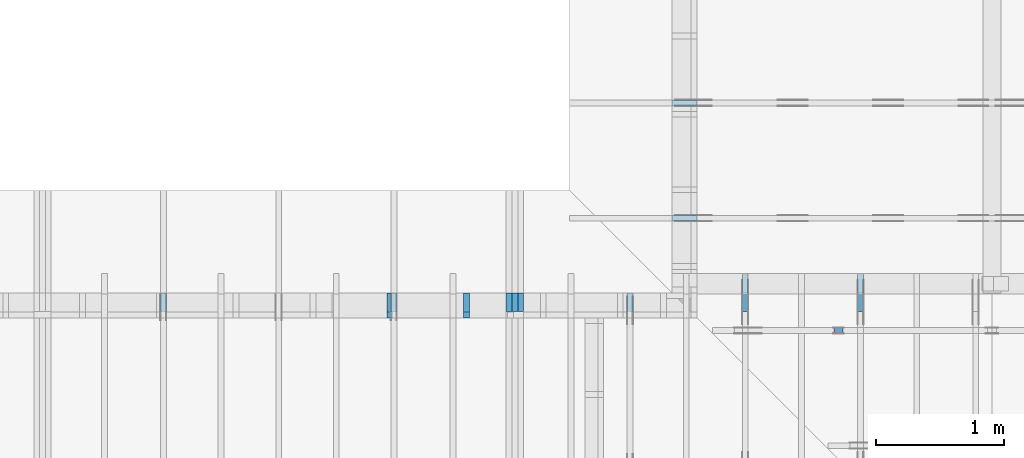
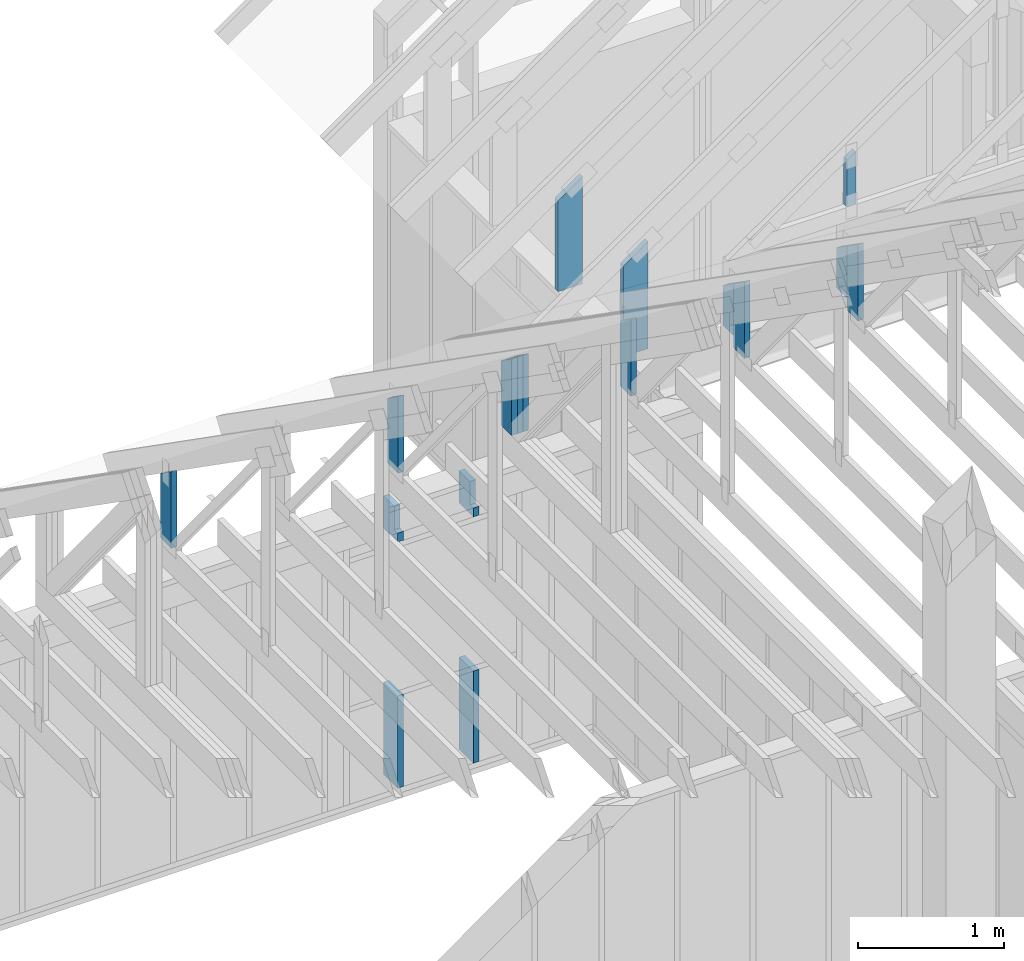
# One storey, part 41 of 70: 17 members, 10 elements without a shape of their own.
"""IFC2X3 building model written with IfcOpenShell, lengths in millimetres."""

from ifc_helpers import new_model, si_unit, frame, origin, origin_with_axes, origin_2d, place, context, project, spatial, faceted_brep, element, aggregate, save


model = new_model("IFC2X3")

# Units and contexts
model_context = context("Model", 3, precision=1e-05, world=origin())
plan_context = context("Plan", 2, precision=1e-05, world=origin_2d())
ifc_project = project(units=[si_unit("LENGTHUNIT", "METRE", prefix="MILLI"), si_unit("AREAUNIT", "SQUARE_METRE"), si_unit("VOLUMEUNIT", "CUBIC_METRE"), si_unit("SOLIDANGLEUNIT", "STERADIAN"), si_unit("PLANEANGLEUNIT", "RADIAN"), si_unit("MASSUNIT", "GRAM"), si_unit("TIMEUNIT", "SECOND"), si_unit("THERMODYNAMICTEMPERATUREUNIT", "DEGREE_CELSIUS"), si_unit("LUMINOUSINTENSITYUNIT", "LUMEN")], contexts=[model_context, plan_context])

# Site, building, storey
site_placement = place(None, origin_with_axes())
site = spatial("IfcSite", under=ifc_project, at=site_placement, CompositionType="ELEMENT")
building_placement = place(site_placement, origin_with_axes())
building = spatial("IfcBuilding", under=site, at=building_placement, Name="Layout 1", CompositionType="ELEMENT")
storey_placement = place(building_placement, origin_with_axes())
storey = spatial("IfcBuildingStorey", under=building, at=storey_placement, Name="Storey 1", CompositionType="ELEMENT", Elevation=0.0)

# Assembly, members
assembly_1_placement = place(storey_placement, frame((5660.000000000293, 8000.0, 9.122500660690286e-13), z_axis=(-1.0, 1.836909530733566e-16, 6.123031769111886e-17), x_axis=(-1.836909530733566e-16, -1.0, 0.0)))
assembly_1 = element("IfcElementAssembly", 1, at=assembly_1_placement, inside=storey, Name="T11", AssemblyPlace="FACTORY", PredefinedType="TRUSS")
member_1_placement = place(assembly_1_placement, frame((145.00000000010297, 220.00000000000085, -90.0), z_axis=(0.0, 0.0, 1.0), x_axis=(-1.7151265217091316e-15, 1.0, 0.0)))
member_1 = element("IfcMember", 2, at=member_1_placement, Name="E3", context=model_context, shape_type="Brep", body=[
    faceted_brep([(541.9489551912696, 145.00000000010203, 45.0), (2.5579538487363607e-13, 145.00000000010203, 45.0), (0.0, 1.9656170024973108e-09, 45.0), (643.4790482318778, 1.9656170024973108e-09, 45.0), (2.5579538487363607e-13, 145.00000000010203, 3.1324865359469514e-29), (541.9489551912696, 145.00000000010203, 6.636741339746276e-14), (643.4790482318778, 1.9656170024973108e-09, 7.880085310163335e-14), (0.0, 1.9656170024973108e-09, 0.0), (2.647930527585373e-25, 1.9656170024973108e-09, -1.6213362742806436e-41), (2.755364296365142e-15, 1.9656170024973108e-09, 45.0), (2.780838981362891e-13, 145.00000000010297, 45.0), (2.7532853384018877e-13, 145.00000000010297, -1.196020916729972e-30), (643.4790482318778, 2.706308139644939e-14, -1.657081071607727e-30), (643.4790482318778, 2.981844569254974e-14, 45.0), (8.416616445392925e-27, 1.965619757861607e-09, 45.0), (0.0, 1.9656170024973108e-09, 0.0), (541.9489551912698, 145.00000000010206, 6.310887241768095e-30), (541.9489551912698, 145.00000000010206, 45.0), (643.4790482318779, 0.0, 45.0), (643.4790482318779, 0.0, 6.310887241768095e-30), (2.5579538487363607e-13, 145.00000000010297, 0.0), (2.5579538487363607e-13, 145.00000000010297, 45.0), (541.9489551912696, 145.00000000010198, 45.0), (541.9489551912696, 145.00000000010198, -4.733165431326071e-30)], [[[0, 1, 2, 3]], [[4, 5, 6, 7]], [[8, 9, 10, 11]], [[12, 13, 14, 15]], [[16, 17, 18, 19]], [[20, 21, 22, 23]]]),
])
member_2_placement = place(assembly_1_placement, frame((145.00000000010297, 220.00000000000085, -135.0), z_axis=(0.0, 0.0, 1.0), x_axis=(-1.7151265217091316e-15, 1.0, 0.0)))
member_2 = element("IfcMember", 3, at=member_2_placement, Name="E3", context=model_context, shape_type="Brep", body=[
    faceted_brep([(541.9489551912696, 145.00000000010203, 45.0), (2.5579538487363607e-13, 145.00000000010203, 45.0), (0.0, 1.9656170024973108e-09, 45.0), (643.4790482318778, 1.9656170024973108e-09, 45.0), (2.5579538487363607e-13, 145.00000000010203, 3.1324865359469514e-29), (541.9489551912696, 145.00000000010203, 6.636741339746276e-14), (643.4790482318778, 1.9656170024973108e-09, 7.880085310163335e-14), (0.0, 1.9656170024973108e-09, 0.0), (2.647930527585373e-25, 1.9656170024973108e-09, -1.6213362742806436e-41), (2.755364296365142e-15, 1.9656170024973108e-09, 45.0), (2.780838981362891e-13, 145.00000000010297, 45.0), (2.7532853384018877e-13, 145.00000000010297, -1.196020916729972e-30), (643.4790482318778, 2.706308139644939e-14, -1.657081071607727e-30), (643.4790482318778, 2.981844569254974e-14, 45.0), (8.416616445392925e-27, 1.965619757861607e-09, 45.0), (0.0, 1.9656170024973108e-09, 0.0), (541.9489551912698, 145.00000000010206, 6.310887241768095e-30), (541.9489551912698, 145.00000000010206, 45.0), (643.4790482318779, 0.0, 45.0), (643.4790482318779, 0.0, 6.310887241768095e-30), (2.5579538487363607e-13, 145.00000000010297, 0.0), (2.5579538487363607e-13, 145.00000000010297, 45.0), (541.9489551912696, 145.00000000010198, 45.0), (541.9489551912696, 145.00000000010198, -4.733165431326071e-30)], [[[0, 1, 2, 3]], [[4, 5, 6, 7]], [[8, 9, 10, 11]], [[12, 13, 14, 15]], [[16, 17, 18, 19]], [[20, 21, 22, 23]]]),
])
member_3_placement = place(assembly_1_placement, frame((145.00000000010297, 220.00000000000085, -180.0), z_axis=(0.0, 0.0, 1.0), x_axis=(-1.7151265217091316e-15, 1.0, 0.0)))
member_3 = element("IfcMember", 4, at=member_3_placement, Name="E3", context=model_context, shape_type="Brep", body=[
    faceted_brep([(541.9489551912696, 145.00000000010203, 45.0), (2.5579538487363607e-13, 145.00000000010203, 45.0), (0.0, 1.9656170024973108e-09, 45.0), (643.4790482318778, 1.9656170024973108e-09, 45.0), (2.5579538487363607e-13, 145.00000000010203, 3.1324865359469514e-29), (541.9489551912696, 145.00000000010203, 6.636741339746276e-14), (643.4790482318778, 1.9656170024973108e-09, 7.880085310163335e-14), (0.0, 1.9656170024973108e-09, 0.0), (2.647930527585373e-25, 1.9656170024973108e-09, -1.6213362742806436e-41), (2.755364296365142e-15, 1.9656170024973108e-09, 45.0), (2.780838981362891e-13, 145.00000000010297, 45.0), (2.7532853384018877e-13, 145.00000000010297, -1.196020916729972e-30), (643.4790482318778, 2.706308139644939e-14, -1.657081071607727e-30), (643.4790482318778, 2.981844569254974e-14, 45.0), (8.416616445392925e-27, 1.965619757861607e-09, 45.0), (0.0, 1.9656170024973108e-09, 0.0), (541.9489551912698, 145.00000000010206, 6.310887241768095e-30), (541.9489551912698, 145.00000000010206, 45.0), (643.4790482318779, 0.0, 45.0), (643.4790482318779, 0.0, 6.310887241768095e-30), (2.5579538487363607e-13, 145.00000000010297, 0.0), (2.5579538487363607e-13, 145.00000000010297, 45.0), (541.9489551912696, 145.00000000010198, 45.0), (541.9489551912696, 145.00000000010198, -4.733165431326071e-30)], [[[0, 1, 2, 3]], [[4, 5, 6, 7]], [[8, 9, 10, 11]], [[12, 13, 14, 15]], [[16, 17, 18, 19]], [[20, 21, 22, 23]]]),
])
aggregate(assembly_1, [member_1, member_2, member_3])

# Assembly, member
assembly_2_placement = place(storey_placement, frame((7000.0, 9505.0, 1.3776821480501744e-15), z_axis=(1.2246063538223773e-16, 1.0, 6.123031769111886e-17), x_axis=(-1.0, 1.2246063538223773e-16, 0.0)))
assembly_2 = element("IfcElementAssembly", 5, at=assembly_2_placement, inside=storey, Name="T4", AssemblyPlace="FACTORY", PredefinedType="TRUSS")
member_4_placement = place(assembly_2_placement, frame((-195.00000000029104, 898.4894251432052, -45.0), z_axis=(0.0, 0.0, 1.0), x_axis=(-1.960047792473607e-15, -1.0, 0.0)))
member_4 = element("IfcMember", 6, at=member_4_placement, Name="E2", context=model_context, shape_type="Brep", body=[
    faceted_brep([(898.4894251432048, 195.0000000002928, 45.0), (136.54046995116335, 195.0000000002928, 45.0), (0.0, 0.0, 45.0), (898.4894251432048, 0.0, 45.0), (136.54046995116335, 195.0000000002928, 1.67208327056088e-14), (898.4894251432048, 195.0000000002928, 1.1002958588725838e-13), (898.4894251432048, 0.0, 1.1002958588725838e-13), (0.0, 0.0, 0.0), (-1.1640850691049727e-14, 8.15101140505067e-15, 8.701351488741532e-31), (-9.383788395138588e-15, 6.5705993712440116e-15, 45.0), (136.54046995116337, 195.00000000029124, 45.0), (136.54046995116337, 195.00000000029124, -3.074169377230906e-30), (898.4894251432048, 2.9190987951436253e-10, 5.452994756240366e-29), (898.4894251432048, 2.9191263487865863e-10, 45.0), (-8.951892333787164e-28, 2.755364296100349e-15, 45.0), (0.0, 0.0, 0.0), (898.4894251432048, 195.0000000002928, 0.0), (898.4894251432048, 195.0000000002928, 45.0), (898.4894251432048, 2.928004505520221e-10, 45.0), (898.4894251432048, 2.928004505520221e-10, 0.0), (136.54046995116332, 195.0000000002913, 0.0), (136.54046995116332, 195.0000000002913, 45.0), (898.4894251432048, 195.00000000029277, 45.0), (898.4894251432048, 195.00000000029277, 0.0)], [[[0, 1, 2, 3]], [[4, 5, 6, 7]], [[8, 9, 10, 11]], [[12, 13, 14, 15]], [[16, 17, 18, 19]], [[20, 21, 22, 23]]]),
])
aggregate(assembly_2, [member_4])

assembly_3_placement = place(storey_placement, frame((7000.0, 8605.0, 1.3776821480501744e-15), z_axis=(1.2246063538223773e-16, 1.0, 6.123031769111886e-17), x_axis=(-1.0, 1.2246063538223773e-16, 0.0)))
assembly_3 = element("IfcElementAssembly", 7, at=assembly_3_placement, inside=storey, Name="T4", AssemblyPlace="FACTORY", PredefinedType="TRUSS")
member_5_placement = place(assembly_3_placement, frame((-195.00000000029104, 898.4894251432052, -45.0), z_axis=(0.0, 0.0, 1.0), x_axis=(-1.960047792473607e-15, -1.0, 0.0)))
member_5 = element("IfcMember", 8, at=member_5_placement, Name="E2", context=model_context, shape_type="Brep", body=[
    faceted_brep([(898.4894251432048, 195.0000000002928, 45.0), (136.54046995116335, 195.0000000002928, 45.0), (0.0, 0.0, 45.0), (898.4894251432048, 0.0, 45.0), (136.54046995116335, 195.0000000002928, 1.67208327056088e-14), (898.4894251432048, 195.0000000002928, 1.1002958588725838e-13), (898.4894251432048, 0.0, 1.1002958588725838e-13), (0.0, 0.0, 0.0), (-1.1640850691049727e-14, 8.15101140505067e-15, 8.701351488741532e-31), (-9.383788395138588e-15, 6.5705993712440116e-15, 45.0), (136.54046995116337, 195.00000000029124, 45.0), (136.54046995116337, 195.00000000029124, -3.074169377230906e-30), (898.4894251432048, 2.9190987951436253e-10, 5.452994756240366e-29), (898.4894251432048, 2.9191263487865863e-10, 45.0), (-8.951892333787164e-28, 2.755364296100349e-15, 45.0), (0.0, 0.0, 0.0), (898.4894251432048, 195.0000000002928, 0.0), (898.4894251432048, 195.0000000002928, 45.0), (898.4894251432048, 2.928004505520221e-10, 45.0), (898.4894251432048, 2.928004505520221e-10, 0.0), (136.54046995116332, 195.0000000002913, 0.0), (136.54046995116332, 195.0000000002913, 45.0), (898.4894251432048, 195.00000000029277, 45.0), (898.4894251432048, 195.00000000029277, 0.0)], [[[0, 1, 2, 3]], [[4, 5, 6, 7]], [[8, 9, 10, 11]], [[12, 13, 14, 15]], [[16, 17, 18, 19]], [[20, 21, 22, 23]]]),
])
aggregate(assembly_3, [member_5])

# Assembly, members
assembly_4_placement = place(storey_placement, frame((6999.999999999999, 8000.0, -2470.0), z_axis=(1.2246063538223773e-16, 1.0, 6.123031769111886e-17), x_axis=(-1.0, 1.2246063538223773e-16, 0.0)))
assembly_4 = element("IfcElementAssembly", 9, at=assembly_4_placement, inside=storey, Name="VE2", AssemblyPlace="FACTORY", PredefinedType="NOTDEFINED")
member_6_placement = place(assembly_4_placement, frame((1582.500000001819, 2425.0, -195.00000000000003), z_axis=(0.0, 0.0, 1.0), x_axis=(-1.836909530733566e-16, -1.0, 0.0)))
member_6 = element("IfcMember", 10, at=member_6_placement, Name="S40", context=model_context, shape_type="Brep", body=[
    faceted_brep([(0.0, 45.00000000001455, 45.00000000000003), (195.00000000186265, 45.00000000001455, 45.00000000000005), (195.00000000186265, 0.0, 45.00000000000005), (0.0, 0.0, 45.00000000000003), (195.00000000186265, 45.00000000001455, 2.842170943040401e-14), (195.00000000186265, 45.00000000001455, 45.00000000000003), (195.00000000186265, 1.0459189070388675e-11, 45.00000000000003), (195.00000000186265, 1.0459189070388675e-11, 2.842170943040401e-14), (2.7553642961003504e-15, -3.3742366240998114e-31, 45.00000000000003), (1.1939911949768181e-14, -1.4621692037765844e-30, 195.00000000000006), (1.7450640541970662e-14, 45.00000000001455, 195.00000000000006), (8.26609288830283e-15, 45.00000000001455, 45.00000000000003), (270.0, -4.959655732980628e-14, 2.842170943040401e-14), (270.0, -3.76566453800381e-14, 195.00000000000003), (2.1932538056648764e-30, 1.193991194976818e-14, 195.00000000000003), (5.061354936149717e-31, 2.7553642961003504e-15, 45.00000000000003), (195.00000000186265, -3.306437155354634e-14, 45.00000000000003), (195.00000000186265, -3.5819735849646686e-14, 2.842170943040401e-14), (-1.6871183120499057e-31, 45.00000000001455, 45.00000000000003), (-7.310846018882921e-31, 45.00000000001454, 195.00000000000003), (270.0, 45.00000000001452, 195.00000000000003), (270.0, 45.00000000001454, 2.8421709430404004e-14), (195.00000000186265, 45.00000000001454, 2.8421709430404004e-14), (195.00000000186265, 45.00000000001454, 45.00000000000003), (270.0, 45.00000000001455, 0.0), (270.0, 45.00000000001455, 195.00000000000003), (270.0, 1.4551915228366852e-11, 195.00000000000003), (270.0, 1.4551915228366852e-11, 0.0), (270.0, 45.00000000001455, 195.00000000000003), (0.0, 45.00000000001455, 195.00000000000003), (0.0, 0.0, 195.00000000000003), (270.0, 0.0, 195.00000000000003), (195.00000000186265, 45.00000000001455, 5.2301533330168465e-14), (270.0, 45.00000000001455, 6.148608098360819e-14), (270.0, 1.4551915228366852e-11, 6.148608098360819e-14), (195.00000000186265, 1.4551915228366852e-11, 5.2301533330168465e-14)], [[[0, 1, 2, 3]], [[4, 5, 6, 7]], [[8, 9, 10, 11]], [[12, 13, 14, 15, 16, 17]], [[18, 19, 20, 21, 22, 23]], [[24, 25, 26, 27]], [[28, 29, 30, 31]], [[32, 33, 34, 35]]]),
])
member_7_placement = place(assembly_4_placement, frame((1582.5000000018192, 863.1713847472129, -195.0), z_axis=(0.0, 0.0, 1.0), x_axis=(-1.836909530733566e-16, -1.0, 0.0)))
member_7 = element("IfcMember", 11, at=member_7_placement, Name="S36", context=model_context, shape_type="Brep", body=[
    faceted_brep([(773.1713847472129, 45.00000000001455, 195.0), (0.0, 45.00000000001455, 195.0), (0.0, 1.432454155292362e-11, 195.0), (773.1713847472129, 1.432454155292362e-11, 195.0), (0.0, 45.00000000001455, 0.0), (773.1713847472129, 45.00000000001455, 9.468305903550827e-14), (773.1713847472129, 1.432454155292362e-11, 9.468305903550827e-14), (0.0, 1.432454155292362e-11, 0.0), (1.7541924601302928e-27, 1.432454155292362e-11, -1.0740976162514319e-43), (1.1939911949769933e-14, 1.432454155292362e-11, 195.0), (1.745064054197063e-14, 45.000000000014325, 195.0), (5.510728592202452e-15, 45.000000000014325, -3.3742366241008834e-31), (773.1713847472129, -2.384799475345207e-13, 1.4602202950499974e-29), (773.1713847472129, -2.2654003558475254e-13, 195.0), (2.2489346847064345e-28, 1.4336481464873388e-11, 195.0), (0.0, 1.432454155292362e-11, 0.0), (773.1713847472129, 45.00000000001455, 0.0), (773.1713847472129, 45.00000000001455, 195.0), (773.1713847472129, 0.0, 195.0), (773.1713847472129, 0.0, 0.0), (0.0, 45.000000000014325, 0.0), (4.733165431326071e-30, 45.00000000001431, 195.0), (773.1713847472129, 45.00000000001461, 195.0), (773.1713847472129, 45.00000000001462, 4.338734978715565e-30)], [[[0, 1, 2, 3]], [[4, 5, 6, 7]], [[8, 9, 10, 11]], [[12, 13, 14, 15]], [[16, 17, 18, 19]], [[20, 21, 22, 23]]]),
])
member_8_placement = place(assembly_4_placement, frame((2182.500000001819, 2425.0, -195.0), z_axis=(0.0, 0.0, 1.0), x_axis=(-1.836909530733566e-16, -1.0, 0.0)))
member_8 = element("IfcMember", 12, at=member_8_placement, Name="S40", context=model_context, shape_type="Brep", body=[
    faceted_brep([(0.0, 45.00000000001455, 45.0), (195.00000000186265, 45.00000000001455, 45.00000000000002), (195.00000000186265, 0.0, 45.00000000000002), (0.0, 0.0, 45.0), (195.00000000186265, 45.00000000001455, 0.0), (195.00000000186265, 45.00000000001455, 45.0), (195.00000000186265, 0.0, 45.0), (195.00000000186265, 0.0, 0.0), (2.755364296100349e-15, -3.3742366240998092e-31, 45.0), (1.193991194976818e-14, -1.4621692037765842e-30, 195.00000000000003), (1.745064054197066e-14, 45.00000000001455, 195.00000000000003), (8.26609288830283e-15, 45.00000000001455, 45.0), (270.0, -4.959655732980628e-14, 3.0368129616898283e-30), (270.0, -3.76566453800381e-14, 195.0), (2.193253805664876e-30, 1.1939911949768178e-14, 195.0), (5.061354936149714e-31, 2.755364296100349e-15, 45.0), (195.00000000186265, -3.306437155354634e-14, 45.0), (195.00000000186265, -3.5819735849646686e-14, 2.193253805685826e-30), (-1.6871183120499046e-31, 45.00000000001455, 45.0), (-7.31084601888292e-31, 45.00000000001454, 195.0), (270.0, 45.00000000001452, 195.0), (270.0, 45.00000000001454, -1.1832913578315177e-30), (195.00000000186265, 45.00000000001454, -7.888609052210118e-31), (195.00000000186265, 45.00000000001454, 45.0), (270.0, 45.00000000001455, 0.0), (270.0, 45.00000000001455, 195.0), (270.0, 0.0, 195.0), (270.0, 0.0, 0.0), (270.0, 45.00000000001455, 195.0), (0.0, 45.00000000001455, 195.0), (0.0, 0.0, 195.0), (270.0, 0.0, 195.0), (195.00000000186265, 45.00000000001455, 2.3879823899764457e-14), (270.0, 45.00000000001455, 3.3064371553204186e-14), (270.0, 0.0, 3.3064371553204186e-14), (195.00000000186265, 0.0, 2.3879823899764457e-14)], [[[0, 1, 2, 3]], [[4, 5, 6, 7]], [[8, 9, 10, 11]], [[12, 13, 14, 15, 16, 17]], [[18, 19, 20, 21, 22, 23]], [[24, 25, 26, 27]], [[28, 29, 30, 31]], [[32, 33, 34, 35]]]),
])
member_9_placement = place(assembly_4_placement, frame((2182.500000001819, 863.1713847472129, -195.0), z_axis=(0.0, 0.0, 1.0), x_axis=(-1.836909530733566e-16, -1.0, 0.0)))
member_9 = element("IfcMember", 13, at=member_9_placement, Name="S36", context=model_context, shape_type="Brep", body=[
    faceted_brep([(773.1713847472129, 45.00000000001455, 195.0), (0.0, 45.00000000001455, 195.0), (0.0, 0.0, 195.0), (773.1713847472129, 0.0, 195.0), (0.0, 45.00000000001455, 0.0), (773.1713847472129, 45.00000000001455, 9.468305903550827e-14), (773.1713847472129, 0.0, 9.468305903550827e-14), (0.0, 0.0, 0.0), (0.0, 0.0, 0.0), (1.1939911949768178e-14, -1.462169203776584e-30, 195.0), (1.745064054197066e-14, 45.00000000001455, 195.0), (5.51072859220248e-15, 45.00000000001455, -3.3742366241009005e-31), (773.1713847472129, -1.420245885532624e-13, 8.696210677066701e-30), (773.1713847472129, -1.3008467660349422e-13, 195.0), (2.193253805664876e-30, 1.1939911949768178e-14, 195.0), (0.0, 0.0, 0.0), (773.1713847472129, 45.00000000001455, 0.0), (773.1713847472129, 45.00000000001455, 195.0), (773.1713847472129, 0.0, 195.0), (773.1713847472129, 0.0, 0.0), (-1.2154326714572542e-63, 45.00000000001455, 0.0), (-7.31084601888292e-31, 45.00000000001454, 195.0), (773.1713847472129, 45.000000000014495, 195.0), (773.1713847472129, 45.0000000000145, -2.7610131682735413e-30)], [[[0, 1, 2, 3]], [[4, 5, 6, 7]], [[8, 9, 10, 11]], [[12, 13, 14, 15]], [[16, 17, 18, 19]], [[20, 21, 22, 23]]]),
])
aggregate(assembly_4, [member_6, member_7, member_8, member_9])

assembly_5_placement = place(storey_placement, frame((8450.0, 8000.0, -9.081170196248781e-13), z_axis=(-1.0, 1.836909530733566e-16, 6.123031769111886e-17), x_axis=(-1.836909530733566e-16, -1.0, 0.0)))
assembly_5 = element("IfcElementAssembly", 14, at=assembly_5_placement, inside=storey, Name="T3", AssemblyPlace="FACTORY", PredefinedType="TRUSS")
member_10_placement = place(assembly_5_placement, frame((145.0000000001018, 220.00000000000097, -45.0), z_axis=(0.0, 0.0, 1.0), x_axis=(6.123031769111886e-17, 1.0, 0.0)))
member_10 = element("IfcMember", 15, at=member_10_placement, Name="E3", context=model_context, shape_type="Brep", body=[
    faceted_brep([(541.9489551912693, 145.00000000010186, 45.0), (0.0, 145.00000000010186, 45.0), (0.0, 1.964451712410664e-09, 45.0), (643.4790482318776, 1.964451712410664e-09, 45.0), (0.0, 145.00000000010186, 0.0), (541.9489551912693, 145.00000000010186, 6.636741339746272e-14), (643.4790482318776, 1.964451712410664e-09, 7.880085310163334e-14), (0.0, 1.964451712410664e-09, 0.0), (2.4056800487953487e-25, 1.964451712410664e-09, -1.4730055365092553e-41), (2.7553642963409167e-15, 1.964451712410664e-09, 45.0), (2.0512156426537286e-14, 145.0000000001018, 45.0), (1.7756792130436937e-14, 145.0000000001018, -1.087254023321813e-30), (643.4790482318776, 4.8214030877080846e-15, -2.952160427766236e-31), (643.4790482318776, 7.576767383808433e-15, 45.0), (8.411721935180507e-27, 1.9644544677749603e-09, 45.0), (0.0, 1.964451712410664e-09, 0.0), (541.9489551912693, 145.00000000010183, -6.310887241768095e-30), (541.9489551912693, 145.00000000010183, 45.0), (643.4790482318776, 0.0, 45.0), (643.4790482318776, 0.0, -6.310887241768095e-30), (0.0, 145.0000000001018, 0.0), (0.0, 145.0000000001018, 45.0), (541.9489551912693, 145.0000000001019, 45.0), (541.9489551912693, 145.0000000001019, 1.5777218104420236e-30)], [[[0, 1, 2, 3]], [[4, 5, 6, 7]], [[8, 9, 10, 11]], [[12, 13, 14, 15]], [[16, 17, 18, 19]], [[20, 21, 22, 23]]]),
])
member_11_placement = place(assembly_5_placement, frame((0.0, 322.49999999813735, -45.0), z_axis=(0.0, 0.0, 1.0), x_axis=(6.123031769111886e-17, 1.0, 0.0)))
member_11 = element("IfcMember", 16, at=member_11_placement, Name="E4", context=model_context, shape_type="Brep", body=[
    faceted_brep([(337.91886215284467, 145.0, 45.0), (0.0, 145.0, 45.0), (0.0, 0.0, 45.0), (439.44895519316196, 0.0, 45.0), (0.0, 145.0, 0.0), (337.91886215284467, 145.0, 4.138175856688016e-14), (439.44895519316196, 0.0, 5.381519827101513e-14), (0.0, 0.0, 0.0), (0.0, 0.0, 0.0), (2.755364296100349e-15, -3.3742366240998092e-31, 45.0), (2.051215642652482e-14, 145.0, 45.0), (1.775679213042447e-14, 145.0, -1.0872540233210496e-30), (439.44895519316196, -8.07227974065227e-14, 6.590243373489615e-30), (439.44895519316196, -7.796743311042235e-14, 45.0), (5.061354936149714e-31, 2.755364296100349e-15, 45.0), (0.0, 0.0, 0.0), (337.91886215284467, 144.99999999999997, 0.0), (337.91886215284467, 144.99999999999997, 45.0), (439.44895519316196, 0.0, 45.0), (439.44895519316196, 0.0, 0.0), (0.0, 145.0, 0.0), (-1.6871183120499046e-31, 145.0, 45.0), (337.91886215284467, 144.99999999999997, 45.0), (337.91886215284467, 144.99999999999997, -1.5777218104420236e-30)], [[[0, 1, 2, 3]], [[4, 5, 6, 7]], [[8, 9, 10, 11]], [[12, 13, 14, 15]], [[16, 17, 18, 19]], [[20, 21, 22, 23]]]),
])
aggregate(assembly_5, [member_10, member_11])

assembly_6_placement = place(storey_placement, frame((7550.000000000001, 8000.0, -9.081170196248781e-13), z_axis=(-1.0, 1.836909530733566e-16, 6.123031769111886e-17), x_axis=(-1.836909530733566e-16, -1.0, 0.0)))
assembly_6 = element("IfcElementAssembly", 17, at=assembly_6_placement, inside=storey, Name="T3", AssemblyPlace="FACTORY", PredefinedType="TRUSS")
member_12_placement = place(assembly_6_placement, frame((145.0000000001018, 220.00000000000097, -45.0), z_axis=(0.0, 0.0, 1.0), x_axis=(6.123031769111886e-17, 1.0, 0.0)))
member_12 = element("IfcMember", 18, at=member_12_placement, Name="E3", context=model_context, shape_type="Brep", body=[
    faceted_brep([(541.9489551912693, 145.00000000010186, 45.0), (0.0, 145.00000000010186, 45.0), (0.0, 1.964451712410664e-09, 45.0), (643.4790482318776, 1.964451712410664e-09, 45.0), (0.0, 145.00000000010186, 0.0), (541.9489551912693, 145.00000000010186, 6.636741339746272e-14), (643.4790482318776, 1.964451712410664e-09, 7.880085310163334e-14), (0.0, 1.964451712410664e-09, 0.0), (2.4056800487953487e-25, 1.964451712410664e-09, -1.4730055365092553e-41), (2.7553642963409167e-15, 1.964451712410664e-09, 45.0), (2.0512156426537286e-14, 145.0000000001018, 45.0), (1.7756792130436937e-14, 145.0000000001018, -1.087254023321813e-30), (643.4790482318776, 4.8214030877080846e-15, -2.952160427766236e-31), (643.4790482318776, 7.576767383808433e-15, 45.0), (8.411721935180507e-27, 1.9644544677749603e-09, 45.0), (0.0, 1.964451712410664e-09, 0.0), (541.9489551912693, 145.00000000010183, -6.310887241768095e-30), (541.9489551912693, 145.00000000010183, 45.0), (643.4790482318776, 0.0, 45.0), (643.4790482318776, 0.0, -6.310887241768095e-30), (0.0, 145.0000000001018, 0.0), (0.0, 145.0000000001018, 45.0), (541.9489551912693, 145.0000000001019, 45.0), (541.9489551912693, 145.0000000001019, 1.5777218104420236e-30)], [[[0, 1, 2, 3]], [[4, 5, 6, 7]], [[8, 9, 10, 11]], [[12, 13, 14, 15]], [[16, 17, 18, 19]], [[20, 21, 22, 23]]]),
])
member_13_placement = place(assembly_6_placement, frame((0.0, 322.49999999813735, -45.0), z_axis=(0.0, 0.0, 1.0), x_axis=(6.123031769111886e-17, 1.0, 0.0)))
member_13 = element("IfcMember", 19, at=member_13_placement, Name="E4", context=model_context, shape_type="Brep", body=[
    faceted_brep([(337.91886215284467, 145.0, 45.0), (0.0, 145.0, 45.0), (0.0, 0.0, 45.0), (439.44895519316196, 0.0, 45.0), (0.0, 145.0, 0.0), (337.91886215284467, 145.0, 4.138175856688016e-14), (439.44895519316196, 0.0, 5.381519827101513e-14), (0.0, 0.0, 0.0), (0.0, 0.0, 0.0), (2.755364296100349e-15, -3.3742366240998092e-31, 45.0), (2.051215642652482e-14, 145.0, 45.0), (1.775679213042447e-14, 145.0, -1.0872540233210496e-30), (439.44895519316196, -8.07227974065227e-14, 6.590243373489615e-30), (439.44895519316196, -7.796743311042235e-14, 45.0), (5.061354936149714e-31, 2.755364296100349e-15, 45.0), (0.0, 0.0, 0.0), (337.91886215284467, 144.99999999999997, 0.0), (337.91886215284467, 144.99999999999997, 45.0), (439.44895519316196, 0.0, 45.0), (439.44895519316196, 0.0, 0.0), (0.0, 145.0, 0.0), (-1.6871183120499046e-31, 145.0, 45.0), (337.91886215284467, 144.99999999999997, 45.0), (337.91886215284467, 144.99999999999997, -1.5777218104420236e-30)], [[[0, 1, 2, 3]], [[4, 5, 6, 7]], [[8, 9, 10, 11]], [[12, 13, 14, 15]], [[16, 17, 18, 19]], [[20, 21, 22, 23]]]),
])
aggregate(assembly_6, [member_12, member_13])

# Assembly, member
assembly_7_placement = place(storey_placement, frame((6650.000000000001, 8000.0, -9.081170196248781e-13), z_axis=(-1.0, 1.836909530733566e-16, 6.123031769111886e-17), x_axis=(-1.836909530733566e-16, -1.0, 0.0)))
assembly_7 = element("IfcElementAssembly", 20, at=assembly_7_placement, inside=storey, Name="T12", AssemblyPlace="FACTORY", PredefinedType="TRUSS")
member_14_placement = place(assembly_7_placement, frame((145.0000000001018, 220.00000000000097, -45.0), z_axis=(0.0, 0.0, 1.0), x_axis=(6.123031769111886e-17, 1.0, 0.0)))
member_14 = element("IfcMember", 21, at=member_14_placement, Name="E3", context=model_context, shape_type="Brep", body=[
    faceted_brep([(541.9489551912693, 145.00000000010186, 45.0), (0.0, 145.00000000010186, 45.0), (0.0, 1.964451712410664e-09, 45.0), (643.4790482318776, 1.964451712410664e-09, 45.0), (0.0, 145.00000000010186, 0.0), (541.9489551912693, 145.00000000010186, 6.636741339746272e-14), (643.4790482318776, 1.964451712410664e-09, 7.880085310163334e-14), (0.0, 1.964451712410664e-09, 0.0), (2.4056800487953487e-25, 1.964451712410664e-09, -1.4730055365092553e-41), (2.7553642963409167e-15, 1.964451712410664e-09, 45.0), (2.0512156426537286e-14, 145.0000000001018, 45.0), (1.7756792130436937e-14, 145.0000000001018, -1.087254023321813e-30), (643.4790482318776, 4.8214030877080846e-15, -2.952160427766236e-31), (643.4790482318776, 7.576767383808433e-15, 45.0), (8.411721935180507e-27, 1.9644544677749603e-09, 45.0), (0.0, 1.964451712410664e-09, 0.0), (541.9489551912693, 145.00000000010183, -6.310887241768095e-30), (541.9489551912693, 145.00000000010183, 45.0), (643.4790482318776, 0.0, 45.0), (643.4790482318776, 0.0, -6.310887241768095e-30), (0.0, 145.0000000001018, 0.0), (0.0, 145.0000000001018, 45.0), (541.9489551912693, 145.0000000001019, 45.0), (541.9489551912693, 145.0000000001019, 1.5777218104420236e-30)], [[[0, 1, 2, 3]], [[4, 5, 6, 7]], [[8, 9, 10, 11]], [[12, 13, 14, 15]], [[16, 17, 18, 19]], [[20, 21, 22, 23]]]),
])
aggregate(assembly_7, [member_14])

assembly_8_placement = place(storey_placement, frame((7294.999999999998, 7682.5, 1206.561223771864), z_axis=(0.0, -1.0, 6.123031769111886e-17), x_axis=(1.0, 0.0, 0.0)))
assembly_8 = element("IfcElementAssembly", 22, at=assembly_8_placement, inside=storey, Name="SB1", AssemblyPlace="FACTORY", PredefinedType="TRUSS")
member_15_placement = place(assembly_8_placement, frame((1040.000000000001, 135.7546696092837, -45.0), z_axis=(0.0, 0.0, 1.0), x_axis=(-1.0489927069340377e-15, 1.0, 0.0)))
member_15 = element("IfcMember", 23, at=member_15_placement, Name="W11", context=model_context, shape_type="Brep", body=[
    faceted_brep([(396.9536918035103, 70.00000000000057, 45.0), (1.6257217794191092e-11, 70.00000000000057, 45.0), (0.0, 9.094947017729282e-13, 45.0), (445.96821947816954, 9.094947017729282e-13, 45.0), (1.6257217794191092e-11, 70.00000000000057, 1.9908692206240624e-27), (396.9536918035103, 70.00000000000057, 4.8611201315582845e-14), (445.96821947816954, 9.094947017729282e-13, 5.461355151758189e-14), (0.0, 9.094947017729282e-13, 0.0), (-1.9081066183098986e-27, 9.094947017729282e-13, 1.1683397442764157e-43), (2.7553642960984406e-15, 9.094947017729276e-13, 45.0), (1.626943358138357e-11, 70.00000000000057, 45.0), (1.6266678217087468e-11, 70.00000000000057, -5.792646994373963e-31), (445.96821947816954, 3.537567767135689e-14, -2.166063982355801e-30), (445.96821947816954, 3.813104196745724e-14, 45.0), (5.400645706032083e-30, 9.122500660690286e-13, 45.0), (0.0, 9.094947017729282e-13, 0.0), (396.9536918035103, 70.00000000000057, 7.006492321624085e-46), (396.9536918035103, 70.00000000000057, 45.0), (445.96821947816954, 2.842170943040401e-14, 45.0), (445.96821947816954, 2.842170943040401e-14, 7.006492321624085e-46), (1.6257217794191092e-11, 70.00000000000057, 0.0), (1.6257217794191092e-11, 70.00000000000057, 45.0), (396.9536918035103, 70.00000000000054, 45.0), (396.9536918035103, 70.00000000000054, -1.5777218104420236e-30)], [[[0, 1, 2, 3]], [[4, 5, 6, 7]], [[8, 9, 10, 11]], [[12, 13, 14, 15]], [[16, 17, 18, 19]], [[20, 21, 22, 23]]]),
])
aggregate(assembly_8, [member_15])

assembly_9_placement = place(storey_placement, frame((4805.0, 8000.000000000001, -4.5336966873841394e-13), z_axis=(-1.0, 1.836909530733566e-16, 6.123031769111886e-17), x_axis=(-1.836909530733566e-16, -1.0, 0.0)))
assembly_9 = element("IfcElementAssembly", 24, at=assembly_9_placement, inside=storey, Name="T1", AssemblyPlace="FACTORY", PredefinedType="TRUSS")
member_16_placement = place(assembly_9_placement, frame((144.99999999911302, 220.0000000000008, -45.0), z_axis=(0.0, 0.0, 1.0), x_axis=(-1.0489927069340377e-15, 1.0, 0.0)))
member_16 = element("IfcMember", 25, at=member_16_placement, Name="E3", context=model_context, shape_type="Brep", body=[
    faceted_brep([(541.9489551912623, 144.99999999911245, 45.0), (1.4210854715202004e-13, 144.99999999911245, 45.0), (0.0, 9.756604413269088e-10, 45.0), (643.4790482311938, 9.756604413269088e-10, 45.0), (1.4210854715202004e-13, 144.99999999911245, 1.7402702977483063e-29), (541.9489551912623, 144.99999999911245, 6.636741339746185e-14), (643.4790482311938, 9.756604413269088e-10, 7.880085310154959e-14), (0.0, 9.756604413269088e-10, 0.0), (2.981491163116663e-26, 9.756604413269088e-10, -1.8255765111089678e-42), (2.755364296130164e-15, 9.756604413269088e-10, 45.0), (1.4929802728119033e-13, 144.99999999911302, 45.0), (1.4654266298508998e-13, 144.99999999911302, -2.715023211380922e-31), (643.4790482311938, -4.957646772847926e-14, 3.0355828690128443e-30), (643.4790482311938, -4.682110343237891e-14, 45.0), (4.177970601815864e-27, 9.756631966912049e-10, 45.0), (0.0, 9.756604413269088e-10, 0.0), (541.9489551912623, 144.9999999991124, 1.183735732928974e-30), (541.9489551912623, 144.9999999991124, 45.0), (643.4790482311938, 0.0, 45.0), (643.4790482311938, 0.0, 2.2746583527538228e-30), (1.4210854715202004e-13, 144.99999999911302, 0.0), (1.4210854715202004e-13, 144.99999999911302, 45.0), (541.9489551912623, 144.9999999991125, 45.0), (541.9489551912623, 144.9999999991125, 3.1554436208840472e-30)], [[[0, 1, 2, 3]], [[4, 5, 6, 7]], [[8, 9, 10, 11]], [[12, 13, 14, 15]], [[16, 17, 18, 19]], [[20, 21, 22, 23]]]),
])
aggregate(assembly_9, [member_16])

assembly_10_placement = place(storey_placement, frame((3005.0000000000005, 8000.0, 1.3776821480501744e-15), z_axis=(-1.0, 1.836909530733566e-16, 6.123031769111886e-17), x_axis=(-1.836909530733566e-16, -1.0, 0.0)))
assembly_10 = element("IfcElementAssembly", 26, at=assembly_10_placement, inside=storey, Name="T1", AssemblyPlace="FACTORY", PredefinedType="TRUSS")
member_17_placement = place(assembly_10_placement, frame((144.99999999911302, 220.0000000000008, -45.0), z_axis=(0.0, 0.0, 1.0), x_axis=(-1.0489927069340377e-15, 1.0, 0.0)))
member_17 = element("IfcMember", 27, at=member_17_placement, Name="E3", context=model_context, shape_type="Brep", body=[
    faceted_brep([(541.9489551912623, 144.99999999911245, 45.0), (1.4210854715202004e-13, 144.99999999911245, 45.0), (0.0, 9.756604413269088e-10, 45.0), (643.4790482311938, 9.756604413269088e-10, 45.0), (1.4210854715202004e-13, 144.99999999911245, 1.7402702977483063e-29), (541.9489551912623, 144.99999999911245, 6.636741339746185e-14), (643.4790482311938, 9.756604413269088e-10, 7.880085310154959e-14), (0.0, 9.756604413269088e-10, 0.0), (2.981491163116663e-26, 9.756604413269088e-10, -1.8255765111089678e-42), (2.755364296130164e-15, 9.756604413269088e-10, 45.0), (1.4929802728119033e-13, 144.99999999911302, 45.0), (1.4654266298508998e-13, 144.99999999911302, -2.715023211380922e-31), (643.4790482311938, -4.957646772847926e-14, 3.0355828690128443e-30), (643.4790482311938, -4.682110343237891e-14, 45.0), (4.177970601815864e-27, 9.756631966912049e-10, 45.0), (0.0, 9.756604413269088e-10, 0.0), (541.9489551912623, 144.9999999991124, 1.183735732928974e-30), (541.9489551912623, 144.9999999991124, 45.0), (643.4790482311938, 0.0, 45.0), (643.4790482311938, 0.0, 2.2746583527538228e-30), (1.4210854715202004e-13, 144.99999999911302, 0.0), (1.4210854715202004e-13, 144.99999999911302, 45.0), (541.9489551912623, 144.9999999991125, 45.0), (541.9489551912623, 144.9999999991125, 3.1554436208840472e-30)], [[[0, 1, 2, 3]], [[4, 5, 6, 7]], [[8, 9, 10, 11]], [[12, 13, 14, 15]], [[16, 17, 18, 19]], [[20, 21, 22, 23]]]),
])
aggregate(assembly_10, [member_17])

save(model, "model.ifc")
